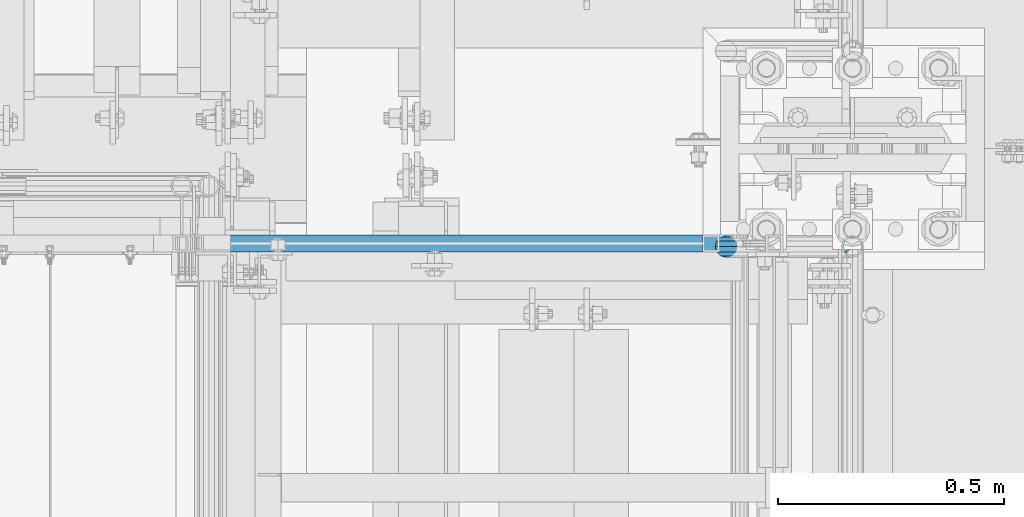
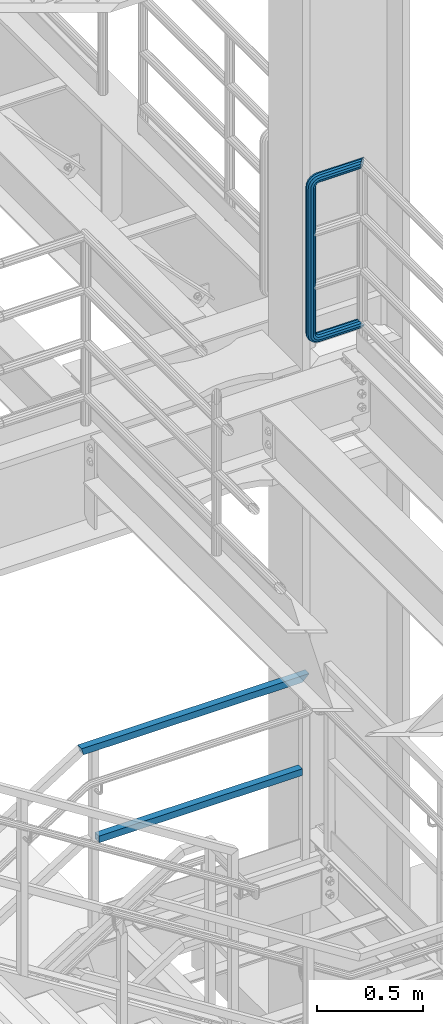
# One storey, part 995 of 1876: 3 beams, 2 elements without a shape of their own.
"""IFC2X3 building model written with IfcOpenShell, lengths in millimetres."""

from ifc_helpers import new_model, si_unit, frame, origin_with_axes, place, context, subcontext, project, spatial, faceted_brep, material, type_object, element, aggregate, save


model = new_model("IFC2X3")

# Units and contexts
model_context = context("Model", 3, precision=1e-05, world=origin_with_axes())
body_context = subcontext(model_context, "Body", "Model", "MODEL_VIEW")
ifc_project = project(units=[si_unit("LENGTHUNIT", "METRE", prefix="MILLI"), si_unit("AREAUNIT", "SQUARE_METRE"), si_unit("VOLUMEUNIT", "CUBIC_METRE"), si_unit("MASSUNIT", "GRAM", prefix="KILO"), si_unit("TIMEUNIT", "SECOND"), si_unit("PLANEANGLEUNIT", "RADIAN"), si_unit("SOLIDANGLEUNIT", "STERADIAN"), si_unit("THERMODYNAMICTEMPERATUREUNIT", "DEGREE_CELSIUS"), si_unit("LUMINOUSINTENSITYUNIT", "LUMEN")], contexts=[model_context])

# Site, building, storey
site_placement = place(None, origin_with_axes())
site = spatial("IfcSite", under=ifc_project, at=site_placement, CompositionType="ELEMENT")
building_placement = place(site_placement, origin_with_axes())
building = spatial("IfcBuilding", under=site, at=building_placement, Name="Undefined", CompositionType="ELEMENT")
storey_placement = place(building_placement, origin_with_axes())
storey = spatial("IfcBuildingStorey", under=building, at=storey_placement, Name="Undefined", CompositionType="ELEMENT", Elevation=0.0)

# Assembly, beam
assembly_1_placement = place(storey_placement, origin_with_axes())
assembly_1 = element("IfcElementAssembly", 1, at=assembly_1_placement, inside=storey, Name="RAIL", AssemblyPlace="NOTDEFINED", PredefinedType="RIGID_FRAME")
ifc_material_1 = material()
beam_type_1 = type_object("IfcBeamType", Name="PIPE1-1/2SCH40", PredefinedType="NOTDEFINED")
beam_1_placement = place(assembly_1_placement, frame((7620.0, -4788.2175, 6207.125), z_axis=(0.0, 0.0, 1.0), x_axis=(-1.0, 0.0, 0.0)))
beam_1 = element("IfcBeam", 2, at=beam_1_placement, type_object=beam_type_1, material=ifc_material_1, Name="RAIL", ObjectType="PIPE1-1/2SCH40", context=body_context, shape_type="Brep", body=[
    faceted_brep([(1.20714750983051e-12, 24.1299999999974, -914.399963378906), (12.0650000000014, 20.8971929933159, -926.464963378905), (12.0650000000014, 20.8971929933177, -902.334963378908), (12.0650000000014, -20.8971929933195, -902.334963378908), (12.0650000000014, -20.8971929933195, -926.464963378905), (1.52133659548828e-12, -24.130000000001, -914.399963378906), (20.8971929933199, -12.0650000000023, -893.502770385589), (20.8971929933199, -12.0650000000005, -898.533841947723), (15.2545715621378, -17.7076214311819, -904.176463378906), (12.5151929933181, -20.4470000000019, -914.399963378906), (15.2545715621376, -17.7076214311819, -924.623463378906), (20.8971929933199, -12.0650000000005, -930.26608481009), (20.8971929933199, -12.0650000000023, -935.297156372224), (24.1300000000014, -1.81898940354586e-12, -934.846963378906), (24.1300000000014, -1.81898940354586e-12, -938.529963378907), (21.3906214311813, -10.2235000000019, -932.107584810088), (21.3906214311823, 10.2234999999982, -932.107584810088), (20.8971929933199, 12.0650000000005, -930.266084810086), (20.8971929933199, 12.0649999999987, -935.297156372224), (15.2545715621413, 17.7076214311783, -924.623463378906), (12.5151929933216, 20.4469999999983, -914.399963378906), (15.2545715621411, 17.7076214311783, -904.176463378906), (20.8971929933199, 12.0650000000005, -898.533841947727), (20.8971929933199, 12.0649999999987, -893.502770385589), (21.3906214311822, 10.2234999999982, -896.692341947724), (24.1300000000014, 0.0, -893.952963378906), (24.1300000000014, 0.0, -890.269963378905), (21.3906214311814, -10.2235000000019, -896.692341947724), (241.299995422363, 20.8971929933177, -12.0649999999987), (241.299995422363, 24.1299999999992, 0.0), (253.073542436527, 24.1299999999992, -1.86474665447167), (249.345252399393, 20.8971929933177, -13.3392435235728), (241.299995422363, 12.0650000000005, -20.8971929933177), (246.615954666858, 12.0650000000005, -21.7391582230448), (241.299995422363, 0.0, -24.130000000001), (245.616962362259, 0.0, -24.8137403926739), (241.299995422363, -12.0650000000005, -20.8971929933177), (246.615954666858, -12.0650000000005, -21.7391582230448), (241.299995422363, -20.8971929933177, -12.0649999999987), (249.345252399393, -20.8971929933177, -13.3392435235728), (241.299995422363, -24.1299999999992, 0.0), (253.073542436527, -24.1299999999992, -1.86474665447167), (241.299995422363, -20.8971929933177, 12.0649999999987), (256.801832473661, -20.8971929933177, 9.60975021462946), (241.299995422363, -12.0650000000005, 20.8971929933177), (259.531130206197, -12.0650000000005, 18.0096649141014), (241.299995422363, 0.0, 24.130000000001), (260.530122510796, 0.0, 21.084247083727), (241.299995422363, 12.0650000000005, 20.8971929933177), (259.531130206197, 12.0650000000005, 18.0096649141014), (241.299995422363, 20.8971929933177, 12.0649999999987), (256.801832473661, 20.8971929933177, 9.60975021462946), (291.464993896486, -20.8971929933177, -38.0999984741211), (279.399993896484, -24.1299999999992, -38.0999984741211), (279.399993896484, -24.1299999999992, -876.299964904785), (291.464993896484, -20.8971929933177, -876.299964904785), (267.334993896485, -20.8971929933177, -38.0999984741211), (267.334993896484, -20.8971929933177, -876.299964904785), (258.502800903167, -12.0650000000005, -38.0999984741211), (258.502800903166, -12.0650000000005, -876.299964904785), (255.269993896485, 0.0, -38.0999984741211), (255.269993896484, 0.0, -876.299964904785), (258.502800903167, 12.0650000000005, -38.0999984741211), (258.502800903166, 12.0650000000005, -876.299964904785), (267.334993896485, 20.8971929933177, -38.0999984741211), (267.334993896484, 20.8971929933177, -876.299964904785), (279.399993896485, 24.1299999999992, -38.0999984741211), (279.399993896484, 24.1299999999992, -876.299964904785), (291.464993896486, 20.8971929933177, -38.0999984741211), (291.464993896484, 20.8971929933177, -876.299964904785), (300.297186889804, 12.0650000000005, -38.0999984741211), (300.297186889803, 12.0650000000005, -876.299964904785), (303.529993896486, 0.0, -38.0999984741211), (303.529993896484, 0.0, -876.299964904785), (300.297186889804, -12.0650000000005, -38.0999984741211), (300.297186889803, -12.0650000000005, -876.299964904785), (297.409658810584, -12.0650000000005, -894.531099688622), (300.484240980214, 0.0, -895.53009199322), (297.409658810584, 12.0650000000005, -894.531099688622), (289.009744111112, 20.8971929933177, -891.801801956084), (277.535247242011, 24.1299999999992, -888.073511918952), (266.06075037291, 20.8971929933177, -884.345221881817), (257.660835673438, 12.0650000000005, -881.615924149282), (254.586253503809, 0.0, -880.616931844681), (257.660835673438, -12.0650000000005, -881.615924149282), (266.06075037291, -20.8971929933177, -884.345221881817), (277.535247242011, -24.130000000001, -888.073511918952), (289.009744111112, -20.8971929933195, -891.801801956084), (241.299995422363, -20.8971929933195, -902.334963378908), (241.299995422363, -12.0650000000005, -893.502770385589), (241.299995422363, -24.130000000001, -914.399963378906), (241.299995422364, -20.8971929933195, -926.464963378909), (241.299995422364, -12.0650000000005, -935.297156372228), (241.299995422364, -1.81898940354586e-12, -938.529963378911), (241.299995422364, 12.0649999999987, -935.297156372228), (241.299995422364, 20.8971929933177, -926.464963378909), (241.299995422364, 24.1299999999992, -914.39996337891), (241.299995422363, 20.8971929933177, -902.334963378908), (241.299995422363, 12.0649999999987, -893.502770385589), (241.299995422363, 0.0, -890.269963378909), (245.61696236226, 0.0, -889.586222986232), (246.615954666859, -12.0650000000005, -892.660805155861), (246.615954666859, 12.0649999999987, -892.660805155861), (249.345252399395, 20.8971929933177, -901.060719855333), (253.07354243653, 24.1299999999992, -912.535216724435), (256.801832473666, 20.8971929933177, -924.009713593536), (259.531130206202, 12.0649999999987, -932.409628293008), (260.530122510801, 0.0, -935.484210462637), (259.531130206201, -12.0650000000005, -932.409628293008), (256.801832473666, -20.8971929933195, -924.009713593536), (253.07354243653, -24.130000000001, -912.535216724435), (249.345252399395, -20.8971929933195, -901.060719855333), (251.411550782037, -12.0650000000005, -890.21732688968), (256.602983568912, -20.8971929933195, -897.362721118872), (249.511354500001, 0.0, -887.601931081743), (251.411550782037, 12.0650000000005, -890.21732688968), (256.602983568912, 20.8971929933177, -897.362721118872), (263.694612637823, 24.1299999999992, -907.123511156005), (270.786241706733, 20.8971929933177, -916.884301193139), (275.977674493594, 12.0649999999987, -924.029695422345), (277.877870775644, 0.0, -926.645091230272), (275.977674493608, -12.0650000000005, -924.029695422334), (270.786241706733, -20.8971929933195, -916.884301193139), (263.694612637823, -24.130000000001, -907.123511156005), (262.362751636451, -20.8971929933195, -891.602953051333), (272.123541673585, -24.130000000001, -898.694582120243), (255.217357407258, -12.0650000000005, -886.411520264461), (252.601961599318, 0.0, -884.511323982424), (255.217357407258, 12.0650000000005, -886.411520264461), (262.362751636451, 20.8971929933177, -891.602953051333), (272.123541673585, 24.1299999999992, -898.694582120243), (281.884331710718, 20.8971929933177, -905.786211189152), (289.029725939912, 12.0650000000005, -910.977643976028), (291.645121747852, 0.0, -912.877840258065), (289.029725939912, -12.0650000000005, -910.977643976028), (281.884331710718, -20.8971929933195, -905.786211189152), (289.009744111112, -20.8971929933177, -22.5981614228222), (297.409658810584, -12.0650000000005, -19.8688636902843), (277.535247242011, -24.1299999999992, -26.3264514599541), (266.060750372911, -20.8971929933177, -30.0547414970897), (257.660835673439, -12.0650000000005, -32.7840392296275), (254.58625350381, 0.0, -33.7830315342253), (257.660835673439, 12.0650000000005, -32.7840392296275), (266.060750372911, 20.8971929933177, -30.0547414970897), (277.535247242011, 24.1299999999992, -26.3264514599541), (289.009744111112, 20.8971929933177, -22.5981614228222), (297.409658810584, 12.0650000000005, -19.8688636902843), (300.484240980213, 0.0, -18.8698713856866), (289.029725939909, -12.0650000000005, -3.42231940287456), (291.645121747848, 0.0, -1.52212312084157), (281.884331710716, -20.8971929933177, -8.61375218975081), (272.123541673583, -24.1299999999992, -15.7053812586601), (262.362751636451, -20.8971929933177, -22.7970103275729), (255.217357407257, -12.0650000000005, -27.9884431144455), (252.601961599318, 0.0, -29.8886393964822), (255.217357407257, 12.0650000000005, -27.9884431144455), (262.362751636451, 20.8971929933177, -22.7970103275729), (272.123541673583, 24.1299999999992, -15.7053812586601), (281.884331710716, 20.8971929933177, -8.61375218975081), (289.029725939909, 12.0650000000005, -3.42231940287456), (277.877870775642, 0.0, 12.2451278513654), (275.977674493607, 12.0650000000005, 9.62973204342416), (275.977674493607, -12.0650000000005, 9.62973204342416), (270.786241706732, -20.8971929933177, 2.48433781423228), (263.694612637822, -24.1299999999992, -7.27645222290084), (256.602983568912, -20.8971929933177, -17.037242260034), (251.411550782037, -12.0650000000005, -24.1826364892258), (249.511354500002, 0.0, -26.7980322971671), (251.411550782037, 12.0650000000005, -24.1826364892258), (256.602983568912, 20.8971929933177, -17.037242260034), (263.694612637822, 24.1299999999992, -7.27645222290084), (270.786241706732, 20.8971929933177, 2.48433781423228), (24.1300000000047, 24.1299999999992, 0.0), (20.8971929933232, 20.8971929933177, 12.0649999999987), (12.0650000000041, 12.0650000000005, 20.8971929933177), (-1.45519152283669e-11, 0.0, 24.130000000001), (-12.0649999999951, -12.0650000000005, 20.8971929933177), (-20.8971929933141, -20.8971929933177, 12.0649999999987), (0.0, -24.1299999999992, 0.0), (-24.1299999999956, -24.1299999999992, 0.0), (-12.0650000000096, -20.8971929933177, -12.0649999999987), (12.0650000000064, -20.8971929933177, -12.0649999999987), (-20.8971929933141, -20.8971929933177, -12.0649999999987), (-12.0649999999951, -12.0650000000005, -20.8971929933177), (20.8971929933249, -12.0650000000005, -20.8971929933177), (-16.481093238739, -16.4810932387427, -16.4810997545756), (24.1300000000063, 0.0, -24.130000000001), (-1.45519152283669e-11, 0.0, -24.130000000001), (20.8971929933249, 12.0650000000005, -20.8971929933177), (12.0650000000041, 12.0650000000005, -20.8971929933177), (20.8971929933232, 20.8971929933177, -12.0649999999987), (16.481099754581, 16.4810997545774, -16.4810932387409), (241.299995422363, -17.7076214311801, 10.2235000000001), (241.299995422363, -20.4470000000001, 0.0), (-20.4469999999956, -20.4470000000001, 0.0), (-17.7076214311755, -17.7076214311801, 10.2235000000001), (241.299995422363, -17.7076214311801, -10.2235000000001), (-17.7076214311755, -17.7076214311801, -10.2235000000001), (241.299995422363, -10.2235000000001, -17.7076214311819), (-10.2234999999955, -10.2235000000001, -17.7076214311819), (241.299995422363, 0.0, -20.4470000000001), (-1.45519152283669e-11, 0.0, -20.4470000000001), (241.299995422363, 10.2235000000001, -17.7076214311819), (10.2235000000046, 10.2235000000001, -17.7076214311819), (241.299995422363, 17.7076214311801, -10.2235000000001), (17.7076214311846, 17.7076214311801, -10.2235000000001), (241.299995422363, 20.4470000000001, 0.0), (20.4470000000047, 20.4470000000001, 0.0), (241.299995422363, 0.0, 20.4470000000001), (241.299995422363, -10.2235000000001, 17.7076214311819), (-10.2234999999955, -10.2235000000001, 17.7076214311819), (-1.45519152283669e-11, 0.0, 20.4470000000001), (241.299995422363, 10.2235000000001, 17.7076214311819), (10.2235000000046, 10.2235000000001, 17.7076214311819), (241.299995422363, 17.7076214311801, 10.2235000000001), (17.7076214311846, 17.7076214311801, 10.2235000000001), (258.545498388721, -10.2235000000001, 14.9762020957387), (256.23277767852, -17.7076214311801, 7.85837963987069), (253.073542436527, -20.4470000000001, -1.86474665447167), (249.914307194535, -17.7076214311801, -11.5878729488177), (247.601586484334, -10.2235000000001, -18.7056954046857), (246.755071952542, 0.0, -21.31099924316), (247.601586484334, 10.2235000000001, -18.7056954046857), (249.914307194535, 17.7076214311801, -11.5878729488177), (253.073542436527, 20.4470000000001, -1.86474665447167), (256.23277767852, 17.7076214311801, 7.85837963987069), (258.545498388721, 10.2235000000001, 14.9762020957387), (259.392012920513, 0.0, 17.5815059342131), (275.713057691449, 0.0, 9.26551826108334), (274.10289136825, -10.2235000000001, 7.04931444488102), (274.10289136825, 10.2235000000001, 7.04931444488102), (269.703835164635, 17.7076214311801, 0.994533019089431), (263.694612637822, 20.4470000000001, -7.27645222290084), (257.685390111009, 17.7076214311801, -15.5474374648911), (253.286333907394, 10.2235000000001, -21.6022188906827), (251.676167584195, 0.0, -23.818422706885), (253.286333907394, -10.2235000000001, -21.6022188906827), (257.685390111009, -17.7076214311801, -15.5474374648911), (263.694612637822, -20.4470000000001, -7.27645222290084), (269.703835164635, -17.7076214311801, 0.994533019089431), (286.449308341364, -10.2235000000001, -5.29710252823133), (280.394526915574, -17.7076214311801, -9.69615873184739), (288.665512157566, 0.0, -3.68693620503473), (286.449308341364, 10.2235000000001, -5.29710252823133), (280.394526915574, 17.7076214311801, -9.69615873184739), (272.123541673583, 20.4470000000001, -15.7053812586601), (263.852556431592, 17.7076214311801, -21.7146037854764), (257.797775005802, 10.2235000000001, -26.1136599890888), (255.581571189601, 0.0, -27.723826312289), (257.797775005802, -10.2235000000001, -26.1136599890888), (263.852556431592, -17.7076214311801, -21.7146037854764), (272.123541673583, -20.4470000000001, -15.7053812586601), (287.258373536355, -17.7076214311801, -23.1672162179639), (277.535247242011, -20.4470000000001, -26.3264514599541), (294.376195992223, -10.2235000000001, -20.8544955077632), (296.981499830698, 0.0, -20.00798097597), (294.376195992223, 10.2235000000001, -20.8544955077632), (287.258373536355, 17.7076214311801, -23.1672162179639), (277.535247242011, 20.4470000000001, -26.3264514599541), (267.812120947668, 17.7076214311801, -29.485686701948), (260.6942984918, 10.2235000000001, -31.7984074121487), (258.088994653325, 0.0, -32.6449219439419), (260.6942984918, -10.2235000000001, -31.7984074121487), (267.812120947668, -17.7076214311801, -29.485686701948), (279.399993896484, -20.4470000000001, -38.0999984741211), (269.176493896485, -17.7076214311801, -38.0999984741211), (289.623493896486, -17.7076214311801, -38.0999984741211), (297.107615327666, -10.2235000000001, -38.0999984741211), (299.846993896486, 0.0, -38.0999984741211), (297.107615327666, 10.2235000000001, -38.0999984741211), (289.623493896486, 17.7076214311801, -38.0999984741211), (279.399993896485, 20.4470000000001, -38.0999984741211), (269.176493896485, 17.7076214311801, -38.0999984741211), (261.692372465305, 10.2235000000001, -38.0999984741211), (258.952993896485, 0.0, -38.0999984741211), (261.692372465305, -10.2235000000001, -38.0999984741211), (269.176493896484, -17.7076214311801, -876.299964904785), (261.692372465304, -10.2235000000001, -876.299964904785), (258.952993896484, 0.0, -876.299964904785), (261.692372465304, 10.2235000000001, -876.299964904785), (269.176493896484, 17.7076214311801, -876.299964904785), (279.399993896484, 20.4470000000001, -876.299964904785), (289.623493896484, 17.7076214311801, -876.299964904785), (297.107615327665, 10.2235000000001, -876.299964904785), (299.846993896484, 0.0, -876.299964904785), (297.107615327665, -10.2235000000001, -876.299964904785), (289.623493896484, -17.7076214311801, -876.299964904785), (279.399993896484, -20.4470000000001, -876.299964904785), (277.535247242011, -20.4470000000001, -888.073511918952), (267.812120947667, -17.7076214311801, -884.914276676958), (260.694298491799, -10.2235000000001, -882.601555966758), (258.088994653324, 0.0, -881.755041434964), (260.694298491799, 10.2235000000001, -882.601555966758), (267.812120947668, 17.7076214311801, -884.914276676958), (277.535247242011, 20.4470000000001, -888.073511918952), (287.258373536355, 17.7076214311801, -891.232747160942), (294.376195992223, 10.2235000000001, -893.545467871143), (296.981499830699, 0.0, -894.391982402936), (294.376195992223, -10.2235000000001, -893.545467871143), (287.258373536355, -17.7076214311801, -891.232747160942), (280.394526915577, -17.7076214311801, -904.703804647055), (272.123541673585, -20.4470000000001, -898.694582120243), (286.449308341367, -10.2235000000001, -909.102860850671), (288.665512157569, 0.0, -910.713027173868), (286.449308341367, 10.2235000000001, -909.102860850671), (280.394526915577, 17.7076214311801, -904.703804647055), (272.123541673585, 20.4470000000001, -898.694582120243), (263.852556431593, 17.7076214311801, -892.68535959343), (257.797775005802, 10.2235000000001, -888.286303389817), (255.581571189601, 0.0, -886.676137066617), (257.797775005802, -10.2235000000001, -888.286303389817), (263.852556431593, -17.7076214311801, -892.68535959343), (263.694612637823, -20.4470000000001, -907.123511156005), (257.685390111009, -17.7076214311801, -898.852525914015), (269.703835164636, -17.7076214311801, -915.394496397999), (274.102891368238, -10.2235000000001, -921.449277823798), (275.71305769145, 0.0, -923.66548163999), (274.102891368251, 10.2235000000001, -921.449277823787), (269.703835164636, 17.7076214311801, -915.394496397999), (263.694612637823, 20.4470000000001, -907.123511156005), (257.685390111009, 17.7076214311801, -898.852525914015), (253.286333907394, 10.2235000000001, -892.797744488227), (251.676167584195, 0.0, -890.581540672025), (253.286333907394, -10.2235000000001, -892.797744488227), (249.914307194537, -17.7076214311801, -902.812090430092), (247.601586484335, -10.2235000000001, -895.694267974224), (253.07354243653, -20.4470000000001, -912.535216724435), (256.232777678524, -17.7076214311819, -922.258343018777), (258.545498388725, -10.2235000000001, -929.376165474645), (259.392012920517, 0.0, -931.981469313119), (258.545498388725, 10.2235000000001, -929.376165474645), (256.232777678524, 17.7076214311801, -922.258343018777), (253.07354243653, 20.4470000000001, -912.535216724435), (249.914307194537, 17.7076214311801, -902.812090430092), (247.601586484335, 10.2235000000001, -895.694267974224), (246.755071952543, 0.0, -893.088964135746), (241.299995422363, -10.2235000000001, -896.692341947728), (241.299995422363, 0.0, -893.95296337891), (241.299995422363, -17.7076214311819, -904.17646337891), (241.299995422363, -20.4470000000001, -914.399963378906), (241.299995422364, -17.7076214311819, -924.62346337891), (241.299995422364, -10.2235000000001, -932.107584810088), (241.299995422364, -1.81898940354586e-12, -934.84696337891), (241.299995422364, 10.2234999999982, -932.107584810088), (241.299995422364, 17.7076214311801, -924.62346337891), (241.299995422364, 20.4470000000001, -914.39996337891), (241.299995422363, 17.7076214311801, -904.17646337891), (241.299995422363, 10.2235000000001, -896.692341947728)], [[[0, 1, 2]], [[3, 4, 5]], [[6, 7, 8, 9, 10, 11, 12, 4, 3]], [[13, 14, 12, 11, 15]], [[16, 17, 18, 14, 13]], [[2, 1, 18, 17, 19, 20, 21, 22, 23]], [[23, 22, 24, 25, 26]], [[26, 25, 27, 7, 6]], [[28, 29, 30, 31]], [[32, 28, 31, 33]], [[34, 32, 33, 35]], [[36, 34, 35, 37]], [[38, 36, 37, 39]], [[40, 38, 39, 41]], [[42, 40, 41, 43]], [[44, 42, 43, 45]], [[46, 44, 45, 47]], [[48, 46, 47, 49]], [[50, 48, 49, 51]], [[52, 53, 54, 55]], [[53, 56, 57, 54]], [[56, 58, 59, 57]], [[58, 60, 61, 59]], [[60, 62, 63, 61]], [[62, 64, 65, 63]], [[64, 66, 67, 65]], [[66, 68, 69, 67]], [[68, 70, 71, 69]], [[70, 72, 73, 71]], [[72, 74, 75, 73]], [[73, 75, 76, 77]], [[71, 73, 77, 78]], [[69, 71, 78, 79]], [[67, 69, 79, 80]], [[65, 67, 80, 81]], [[63, 65, 81, 82]], [[61, 63, 82, 83]], [[59, 61, 83, 84]], [[57, 59, 84, 85]], [[54, 57, 85, 86]], [[55, 54, 86, 87]], [[88, 89, 6, 3]], [[90, 88, 3, 5]], [[91, 90, 5, 4]], [[92, 91, 4, 12]], [[93, 92, 12, 14]], [[94, 93, 14, 18]], [[95, 94, 18, 1]], [[96, 95, 1, 0]], [[97, 96, 0, 2]], [[98, 97, 2, 23]], [[99, 98, 23, 26]], [[89, 99, 26, 6]], [[100, 99, 89, 101]], [[102, 98, 99, 100]], [[103, 97, 98, 102]], [[104, 96, 97, 103]], [[105, 95, 96, 104]], [[106, 94, 95, 105]], [[107, 93, 94, 106]], [[108, 92, 93, 107]], [[109, 91, 92, 108]], [[110, 90, 91, 109]], [[111, 88, 90, 110]], [[101, 89, 88, 111]], [[112, 101, 111, 113]], [[114, 100, 101, 112]], [[115, 102, 100, 114]], [[116, 103, 102, 115]], [[117, 104, 103, 116]], [[118, 105, 104, 117]], [[119, 106, 105, 118]], [[120, 107, 106, 119]], [[121, 108, 107, 120]], [[122, 109, 108, 121]], [[123, 110, 109, 122]], [[113, 111, 110, 123]], [[124, 113, 123, 125]], [[126, 112, 113, 124]], [[127, 114, 112, 126]], [[128, 115, 114, 127]], [[129, 116, 115, 128]], [[130, 117, 116, 129]], [[131, 118, 117, 130]], [[132, 119, 118, 131]], [[133, 120, 119, 132]], [[134, 121, 120, 133]], [[135, 122, 121, 134]], [[125, 123, 122, 135]], [[86, 125, 135, 87]], [[85, 124, 125, 86]], [[84, 126, 124, 85]], [[83, 127, 126, 84]], [[82, 128, 127, 83]], [[81, 129, 128, 82]], [[80, 130, 129, 81]], [[79, 131, 130, 80]], [[78, 132, 131, 79]], [[77, 133, 132, 78]], [[76, 134, 133, 77]], [[87, 135, 134, 76]], [[75, 55, 87, 76]], [[74, 52, 55, 75]], [[136, 52, 74, 137]], [[138, 53, 52, 136]], [[139, 56, 53, 138]], [[140, 58, 56, 139]], [[141, 60, 58, 140]], [[142, 62, 60, 141]], [[143, 64, 62, 142]], [[144, 66, 64, 143]], [[145, 68, 66, 144]], [[146, 70, 68, 145]], [[147, 72, 70, 146]], [[137, 74, 72, 147]], [[148, 137, 147, 149]], [[150, 136, 137, 148]], [[151, 138, 136, 150]], [[152, 139, 138, 151]], [[153, 140, 139, 152]], [[154, 141, 140, 153]], [[155, 142, 141, 154]], [[156, 143, 142, 155]], [[157, 144, 143, 156]], [[158, 145, 144, 157]], [[159, 146, 145, 158]], [[149, 147, 146, 159]], [[160, 149, 159, 161]], [[162, 148, 149, 160]], [[163, 150, 148, 162]], [[164, 151, 150, 163]], [[165, 152, 151, 164]], [[166, 153, 152, 165]], [[167, 154, 153, 166]], [[168, 155, 154, 167]], [[169, 156, 155, 168]], [[170, 157, 156, 169]], [[171, 158, 157, 170]], [[161, 159, 158, 171]], [[49, 161, 171, 51]], [[47, 160, 161, 49]], [[45, 162, 160, 47]], [[43, 163, 162, 45]], [[41, 164, 163, 43]], [[39, 165, 164, 41]], [[37, 166, 165, 39]], [[35, 167, 166, 37]], [[33, 168, 167, 35]], [[31, 169, 168, 33]], [[30, 170, 169, 31]], [[51, 171, 170, 30]], [[29, 50, 51, 30]], [[50, 29, 172, 173]], [[48, 50, 173, 174]], [[46, 48, 174, 175]], [[44, 46, 175, 176]], [[42, 44, 176, 177]], [[178, 40, 42, 177, 179]], [[180, 181, 38, 40, 178, 179, 182]], [[183, 184, 36, 38, 181, 180, 182, 185]], [[186, 34, 36, 184, 183, 187]], [[188, 32, 34, 186, 187, 189]], [[190, 28, 32, 188, 189, 191]], [[29, 28, 190, 172]], [[192, 193, 194, 195]], [[193, 196, 197, 194]], [[196, 198, 199, 197]], [[198, 200, 201, 199]], [[200, 202, 203, 201]], [[202, 204, 205, 203]], [[204, 206, 207, 205]], [[208, 209, 210, 211]], [[212, 208, 211, 213]], [[214, 212, 213, 215]], [[206, 214, 215, 207]], [[191, 189, 187, 183, 185, 182, 179, 177, 176, 175, 174, 173, 172, 190], [213, 211, 210, 195, 194, 197, 199, 201, 203, 205, 207, 215]], [[209, 192, 195, 210]], [[192, 209, 216, 217]], [[193, 192, 217, 218]], [[196, 193, 218, 219]], [[198, 196, 219, 220]], [[200, 198, 220, 221]], [[202, 200, 221, 222]], [[204, 202, 222, 223]], [[206, 204, 223, 224]], [[214, 206, 224, 225]], [[212, 214, 225, 226]], [[208, 212, 226, 227]], [[209, 208, 227, 216]], [[227, 228, 229, 216]], [[226, 230, 228, 227]], [[225, 231, 230, 226]], [[224, 232, 231, 225]], [[223, 233, 232, 224]], [[222, 234, 233, 223]], [[221, 235, 234, 222]], [[220, 236, 235, 221]], [[219, 237, 236, 220]], [[218, 238, 237, 219]], [[217, 239, 238, 218]], [[216, 229, 239, 217]], [[229, 240, 241, 239]], [[228, 242, 240, 229]], [[230, 243, 242, 228]], [[231, 244, 243, 230]], [[232, 245, 244, 231]], [[233, 246, 245, 232]], [[234, 247, 246, 233]], [[235, 248, 247, 234]], [[236, 249, 248, 235]], [[237, 250, 249, 236]], [[238, 251, 250, 237]], [[239, 241, 251, 238]], [[241, 252, 253, 251]], [[240, 254, 252, 241]], [[242, 255, 254, 240]], [[243, 256, 255, 242]], [[244, 257, 256, 243]], [[245, 258, 257, 244]], [[246, 259, 258, 245]], [[247, 260, 259, 246]], [[248, 261, 260, 247]], [[249, 262, 261, 248]], [[250, 263, 262, 249]], [[251, 253, 263, 250]], [[253, 264, 265, 263]], [[252, 266, 264, 253]], [[254, 267, 266, 252]], [[255, 268, 267, 254]], [[256, 269, 268, 255]], [[257, 270, 269, 256]], [[258, 271, 270, 257]], [[259, 272, 271, 258]], [[260, 273, 272, 259]], [[261, 274, 273, 260]], [[262, 275, 274, 261]], [[263, 265, 275, 262]], [[275, 265, 276, 277]], [[274, 275, 277, 278]], [[273, 274, 278, 279]], [[272, 273, 279, 280]], [[271, 272, 280, 281]], [[270, 271, 281, 282]], [[269, 270, 282, 283]], [[268, 269, 283, 284]], [[267, 268, 284, 285]], [[266, 267, 285, 286]], [[264, 266, 286, 287]], [[265, 264, 287, 276]], [[276, 287, 288, 289]], [[277, 276, 289, 290]], [[278, 277, 290, 291]], [[279, 278, 291, 292]], [[280, 279, 292, 293]], [[281, 280, 293, 294]], [[282, 281, 294, 295]], [[283, 282, 295, 296]], [[284, 283, 296, 297]], [[285, 284, 297, 298]], [[286, 285, 298, 299]], [[287, 286, 299, 288]], [[299, 300, 301, 288]], [[298, 302, 300, 299]], [[297, 303, 302, 298]], [[296, 304, 303, 297]], [[295, 305, 304, 296]], [[294, 306, 305, 295]], [[293, 307, 306, 294]], [[292, 308, 307, 293]], [[291, 309, 308, 292]], [[290, 310, 309, 291]], [[289, 311, 310, 290]], [[288, 301, 311, 289]], [[301, 312, 313, 311]], [[300, 314, 312, 301]], [[302, 315, 314, 300]], [[303, 316, 315, 302]], [[304, 317, 316, 303]], [[305, 318, 317, 304]], [[306, 319, 318, 305]], [[307, 320, 319, 306]], [[308, 321, 320, 307]], [[309, 322, 321, 308]], [[310, 323, 322, 309]], [[311, 313, 323, 310]], [[313, 324, 325, 323]], [[312, 326, 324, 313]], [[314, 327, 326, 312]], [[315, 328, 327, 314]], [[316, 329, 328, 315]], [[317, 330, 329, 316]], [[318, 331, 330, 317]], [[319, 332, 331, 318]], [[320, 333, 332, 319]], [[321, 334, 333, 320]], [[322, 335, 334, 321]], [[323, 325, 335, 322]], [[325, 336, 337, 335]], [[324, 338, 336, 325]], [[326, 339, 338, 324]], [[327, 340, 339, 326]], [[328, 341, 340, 327]], [[329, 342, 341, 328]], [[330, 343, 342, 329]], [[331, 344, 343, 330]], [[332, 345, 344, 331]], [[333, 346, 345, 332]], [[334, 347, 346, 333]], [[335, 337, 347, 334]], [[347, 337, 25, 24]], [[21, 346, 347, 24, 22]], [[345, 346, 21, 20]], [[344, 345, 20, 19]], [[343, 344, 19, 17, 16]], [[342, 343, 16, 13]], [[341, 342, 13, 15]], [[10, 340, 341, 15, 11]], [[339, 340, 10, 9]], [[338, 339, 9, 8]], [[336, 338, 8, 7, 27]], [[337, 336, 27, 25]]]),
])
aggregate(assembly_1, [beam_1])

# Assembly, beams
assembly_2_placement = place(storey_placement, origin_with_axes())
assembly_2 = element("IfcElementAssembly", 3, at=assembly_2_placement, inside=storey, Name="RAIL", AssemblyPlace="NOTDEFINED", PredefinedType="RIGID_FRAME")
ifc_material_2 = material()
beam_type_2 = type_object("IfcBeamType", Name="HSS1-1/2X1-1/2X1/8", PredefinedType="NOTDEFINED")
beam_2_placement = place(assembly_2_placement, frame((6166.24687501248, -4781.55000114554, 2837.68362061127), z_axis=(0.0, 0.0, 1.0), x_axis=(1.0, 0.0, 0.0)))
beam_2 = element("IfcBeam", 4, at=beam_2_placement, type_object=beam_type_2, material=ifc_material_2, Name="RAIL", ObjectType="HSS1-1/2X1-1/2X1/8", context=body_context, shape_type="Brep", body=[
    faceted_brep([(19.0500000000002, 15.8749992829999, -15.8749992829999), (19.0500000000002, -15.8749992829999, -15.8749992829999), (1121.96562576452, -15.8749992829999, -15.8749992829999), (1121.96562576452, 15.8749992829999, -15.8749992829999), (19.0500000000002, -15.8749992829999, 15.8749992829999), (1121.96562576452, -15.8749992829999, 15.8749992829999), (19.0500000000002, 15.8749992829999, 15.8749992829999), (1121.96562576452, 15.8749992829999, 15.8749992829999), (19.0500000000002, 19.0499992349996, -19.0499992350001), (19.0500000000002, 19.0499992349996, 19.0499992350001), (1121.96562576452, 19.0499992349996, 19.0499992350001), (1121.96562576452, 19.0499992349996, -19.0499992350001), (19.0500000000002, -19.0499992349996, 19.0499992350001), (1121.96562576452, -19.0499992349996, 19.0499992350001), (19.0500000000002, -19.0499992349996, -19.0499992350001), (1121.96562576452, -19.0499992349996, -19.0499992350001)], [[[0, 1, 2, 3]], [[1, 4, 5, 2]], [[4, 6, 7, 5]], [[6, 0, 3, 7]], [[8, 9, 10, 11]], [[9, 12, 13, 10]], [[12, 14, 15, 13]], [[14, 8, 11, 15]], [[13, 15, 11, 10], [5, 7, 3, 2]], [[12, 9, 8, 14], [4, 1, 0, 6]]]),
])
beam_3_placement = place(assembly_2_placement, frame((7326.312499247, -4781.55000114554, 3371.08362061127), z_axis=(0.0, 0.0, -1.0), x_axis=(-1.0, 0.0, 0.0)))
beam_3 = element("IfcBeam", 5, at=beam_3_placement, type_object=beam_type_2, material=ifc_material_2, Name="RAIL", ObjectType="HSS1-1/2X1-1/2X1/8", context=body_context, shape_type="Brep", body=[
    faceted_brep([(3.17499995199978, 15.8749992829999, -15.8749992829999), (3.17499995199978, -15.8749992829999, -15.8749992829999), (1234.92329369247, -15.8749992829999, -15.8749992829999), (1234.92329369247, 15.8749992829999, -15.8749992829999), (34.9249985179995, -15.8749992829999, 15.8749992829999), (1225.70170403267, -15.8749992829999, 15.8749992829999), (34.9249985179995, 15.8749992829999, 15.8749992829999), (1225.70170403267, 15.8749992829999, 15.8749992829999), (0.0, 19.0499992349996, -19.0499992350001), (38.0999984699993, 19.0499992349996, 19.0499992350001), (1224.77954503898, 19.0499992349996, 19.0499992350001), (1235.84545268616, 19.0499992349996, -19.0499992350001), (38.0999984699993, -19.0499992349996, 19.0499992350001), (1224.77954503898, -19.0499992349996, 19.0499992350001), (0.0, -19.0499992349996, -19.0499992350001), (1235.84545268616, -19.0499992349996, -19.0499992350001)], [[[0, 1, 2, 3]], [[1, 4, 5, 2]], [[4, 6, 7, 5]], [[6, 0, 3, 7]], [[8, 9, 10, 11]], [[9, 12, 13, 10]], [[12, 14, 15, 13]], [[14, 8, 11, 15]], [[13, 15, 11, 10], [5, 7, 3, 2]], [[14, 12, 9, 8], [6, 4, 1, 0]]]),
])
aggregate(assembly_2, [beam_2, beam_3])

save(model, "model.ifc")
